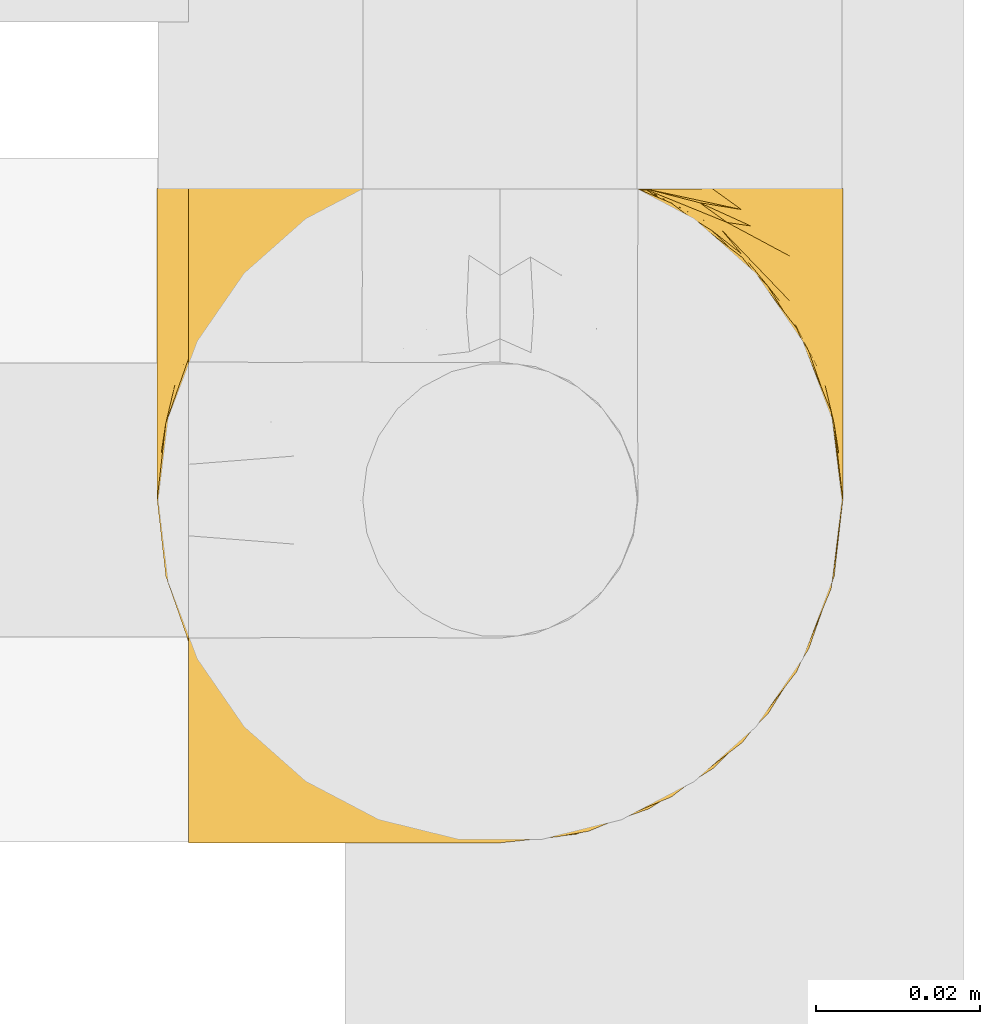
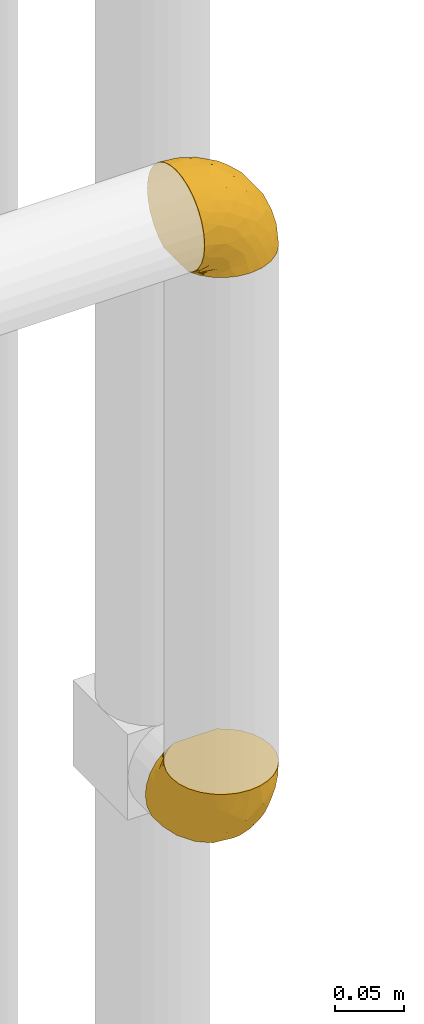
# One storey, part 352 of 827: 2 coverings.
"""IFC2X3 building model written with IfcOpenShell, lengths in millimetres."""

from ifc_helpers import new_model, entity, si_unit, converted_unit, derived_unit, direction, frame, origin, place, context, subcontext, project, spatial, faceted_brep, element, save


model = new_model("IFC2X3")

# Units and contexts
model_context = context("Model", 3, precision=0.01, world=origin(), true_north=direction((6.12303176911189e-17, 1.0)))
body_context = subcontext(model_context, "Body", "Model", "MODEL_VIEW")
ifc_project = project(units=[si_unit("LENGTHUNIT", "METRE", prefix="MILLI"), si_unit("AREAUNIT", "SQUARE_METRE"), si_unit("VOLUMEUNIT", "CUBIC_METRE"), converted_unit("PLANEANGLEUNIT", "DEGREE", entity("IfcRatioMeasure", 0.0174532925199433), si_unit("PLANEANGLEUNIT", "RADIAN"), dimensions=[0, 0, 0, 0, 0, 0, 0]), si_unit("MASSUNIT", "GRAM", prefix="KILO"), derived_unit("MASSDENSITYUNIT", [(si_unit("MASSUNIT", "GRAM", prefix="KILO"), 1), (si_unit("LENGTHUNIT", "METRE"), -3)]), derived_unit("MOMENTOFINERTIAUNIT", [(si_unit("LENGTHUNIT", "METRE"), 4)]), si_unit("TIMEUNIT", "SECOND"), si_unit("FREQUENCYUNIT", "HERTZ"), si_unit("THERMODYNAMICTEMPERATUREUNIT", "DEGREE_CELSIUS"), derived_unit("THERMALTRANSMITTANCEUNIT", [(si_unit("MASSUNIT", "GRAM", prefix="KILO"), 1), (si_unit("THERMODYNAMICTEMPERATUREUNIT", "KELVIN"), -1), (si_unit("TIMEUNIT", "SECOND"), -3)]), derived_unit("VOLUMETRICFLOWRATEUNIT", [(si_unit("LENGTHUNIT", "METRE"), 3), (si_unit("TIMEUNIT", "SECOND"), -1)]), derived_unit("MASSFLOWRATEUNIT", [(si_unit("MASSUNIT", "GRAM", prefix="KILO"), 1), (si_unit("TIMEUNIT", "SECOND"), -1)]), derived_unit("ROTATIONALFREQUENCYUNIT", [(si_unit("TIMEUNIT", "SECOND"), -1)]), si_unit("ELECTRICCURRENTUNIT", "AMPERE"), si_unit("ELECTRICVOLTAGEUNIT", "VOLT"), si_unit("POWERUNIT", "WATT"), si_unit("FORCEUNIT", "NEWTON", prefix="KILO"), si_unit("ILLUMINANCEUNIT", "LUX"), si_unit("LUMINOUSFLUXUNIT", "LUMEN"), si_unit("LUMINOUSINTENSITYUNIT", "CANDELA"), derived_unit("USERDEFINED", [(si_unit("MASSUNIT", "GRAM", prefix="KILO"), -1), (si_unit("LENGTHUNIT", "METRE"), -2), (si_unit("TIMEUNIT", "SECOND"), 3), (si_unit("LUMINOUSFLUXUNIT", "LUMEN"), 1)]), derived_unit("LINEARVELOCITYUNIT", [(si_unit("LENGTHUNIT", "METRE"), 1), (si_unit("TIMEUNIT", "SECOND"), -1)]), si_unit("PRESSUREUNIT", "PASCAL"), derived_unit("USERDEFINED", [(si_unit("LENGTHUNIT", "METRE"), -2), (si_unit("MASSUNIT", "GRAM", prefix="KILO"), 1), (si_unit("TIMEUNIT", "SECOND"), -2)]), derived_unit("LINEARFORCEUNIT", [(si_unit("MASSUNIT", "GRAM", prefix="KILO"), 1), (si_unit("LENGTHUNIT", "METRE"), 1), (si_unit("TIMEUNIT", "SECOND"), -2), (si_unit("LENGTHUNIT", "METRE"), -1)]), derived_unit("PLANARFORCEUNIT", [(si_unit("MASSUNIT", "GRAM", prefix="KILO"), 1), (si_unit("LENGTHUNIT", "METRE"), 1), (si_unit("TIMEUNIT", "SECOND"), -2), (si_unit("LENGTHUNIT", "METRE"), -2)])], contexts=[model_context])

# Site, building, storey
site_placement = place(None, origin())
site = spatial("IfcSite", under=ifc_project, at=site_placement, CompositionType="ELEMENT")
building_placement = place(site_placement, origin())
building = spatial("IfcBuilding", under=site, at=building_placement, CompositionType="ELEMENT")
storey_placement = place(building_placement, frame((0.0, 0.0, 28200.0)))
storey = spatial("IfcBuildingStorey", under=building, at=storey_placement, Name="08", CompositionType="ELEMENT", Elevation=28200.0)

# Coverings
covering_1_placement = place(storey_placement, frame((43532.77, 15137.81, 1655.84)))
element("IfcCovering", 1, at=covering_1_placement, inside=storey, Name=":ADSK_", ObjectType=":ADSK_", PredefinedType="INSULATION", context=body_context, shape_type="Brep", body=[
    faceted_brep([(5.74, 25.28, 81.45), (10.73, 17.35, 81.45), (17.36, 10.72, 81.45), (25.29, 5.74, 81.45), (34.14, 2.64, 81.45), (43.45, 1.6, 81.45), (52.76, 2.65, 81.45), (61.61, 5.74, 81.45), (69.54, 10.73, 81.45), (76.17, 17.36, 81.45), (81.15, 25.29, 81.45), (84.25, 34.14, 81.45), (85.3, 43.45, 81.45), (84.23, 52.82, 81.45), (81.1, 61.71, 81.45), (76.06, 69.67, 81.45), (69.36, 76.31, 81.45), (61.36, 81.27, 81.45), (60.44, 81.27, 81.45), (59.52, 81.27, 81.45), (58.72, 81.27, 81.45), (57.4, 81.27, 81.45), (56.08, 81.27, 81.45), (54.76, 81.27, 81.45), (53.44, 81.27, 81.45), (52.12, 81.27, 81.45), (50.8, 81.27, 81.45), (49.47, 81.27, 81.45), (48.15, 81.27, 81.45), (46.83, 81.27, 81.45), (45.51, 81.27, 81.45), (44.19, 81.27, 81.45), (42.87, 81.27, 81.45), (41.55, 81.27, 81.45), (40.23, 81.27, 81.45), (39.31, 81.27, 81.45), (38.39, 81.27, 81.45), (37.48, 81.27, 81.45), (36.56, 81.27, 81.45), (35.64, 81.27, 81.45), (34.72, 81.27, 81.45), (33.8, 81.27, 81.45), (32.88, 81.27, 81.45), (31.96, 81.27, 81.45), (31.05, 81.27, 81.45), (30.13, 81.27, 81.45), (29.21, 81.27, 81.45), (28.29, 81.27, 81.45), (27.37, 81.27, 81.45), (26.45, 81.27, 81.45), (25.53, 81.27, 81.45), (17.52, 76.3, 81.45), (10.82, 69.66, 81.45), (5.78, 61.69, 81.45), (2.65, 52.8, 81.45), (1.6, 43.45, 81.45), (2.65, 34.13, 81.45), (69.37, 81.45, 76.3), (76.06, 81.45, 69.67), (81.1, 81.45, 61.7), (84.23, 81.45, 52.81), (85.3, 81.45, 43.45), (83.87, 81.45, 32.61), (79.69, 81.45, 22.52), (73.04, 81.45, 13.85), (64.37, 81.45, 7.2), (54.28, 81.45, 3.02), (43.45, 81.45, 1.6), (32.61, 81.45, 3.02), (22.52, 81.45, 7.2), (13.85, 81.45, 13.85), (7.2, 81.45, 22.52), (3.02, 81.45, 32.61), (1.6, 81.45, 43.45), (2.66, 81.45, 52.81), (5.79, 81.45, 61.7), (10.83, 81.45, 69.67), (17.52, 81.45, 76.3), (25.53, 81.45, 81.27), (26.45, 81.45, 81.27), (27.77, 81.45, 81.27), (28.89, 81.45, 81.27), (30.01, 81.45, 81.27), (31.13, 81.45, 81.27), (32.25, 81.45, 81.27), (33.37, 81.45, 81.27), (34.49, 81.45, 81.27), (35.61, 81.45, 81.27), (36.73, 81.45, 81.27), (37.85, 81.45, 81.27), (38.97, 81.45, 81.27), (40.09, 81.45, 81.27), (41.21, 81.45, 81.27), (42.33, 81.45, 81.27), (43.45, 81.45, 81.27), (44.77, 81.45, 81.27), (46.09, 81.45, 81.27), (47.41, 81.45, 81.27), (48.73, 81.45, 81.27), (50.05, 81.45, 81.27), (51.37, 81.45, 81.27), (52.69, 81.45, 81.27), (54.01, 81.45, 81.27), (54.93, 81.45, 81.27), (55.85, 81.45, 81.27), (56.76, 81.45, 81.27), (57.68, 81.45, 81.27), (58.6, 81.45, 81.27), (59.52, 81.45, 81.27), (60.44, 81.45, 81.27), (61.36, 81.45, 81.27), (32.81, 81.33, 81.31), (31.73, 81.32, 81.33), (50.71, 81.33, 81.31), (51.76, 81.32, 81.32), (42.89, 81.33, 81.31), (41.81, 81.32, 81.32), (25.53, 81.32, 81.32), (26.91, 81.32, 81.32), (40.71, 81.32, 81.32), (60.15, 81.32, 81.32), (39.53, 81.32, 81.32), (57.22, 81.32, 81.32), (58.17, 81.34, 81.3), (47.12, 81.32, 81.32), (33.93, 81.31, 81.33), (35.05, 81.33, 81.31), (46.09, 81.31, 81.33), (45.02, 81.32, 81.32), (43.95, 81.33, 81.32), (59.12, 81.32, 81.32), (38.49, 81.33, 81.31), (49.68, 81.32, 81.32), (53.35, 81.33, 81.31), (54.4, 81.32, 81.32), (56.2, 81.32, 81.32), (36.2, 81.32, 81.32), (37.29, 81.31, 81.33), (30.57, 81.32, 81.32), (29.45, 81.33, 81.31), (28.01, 81.31, 81.33), (61.36, 81.32, 81.32), (25.53, 81.3, 81.36), (25.53, 81.29, 81.4), (61.36, 81.29, 81.4), (61.36, 81.3, 81.36), (25.53, 81.4, 81.29), (25.53, 81.36, 81.3), (61.36, 81.36, 81.3), (61.36, 81.4, 81.29), (55.3, 81.3, 81.35), (48.18, 81.33, 81.31), (82.92, 74.06, 58.5), (85.3, 45.99, 71.95), (82.92, 58.35, 74.57), (78.8, 67.76, 73.93), (78.8, 66.18, 78.18), (70.46, 76.46, 78.04), (71.16, 77.33, 76.23), (85.3, 71.95, 45.99), (76.1, 72.25, 74.01), (72.9, 78.91, 73.57), (78.81, 76.42, 66.66), (72.89, 73.52, 79.09), (74.06, 76.9, 73.14), (83.71, 65.25, 60.34), (85.3, 62.45, 48.54), (85.3, 74.31, 45.36), (83.61, 59.38, 67.22), (85.3, 48.54, 62.45), (80.61, 67.72, 68.67), (85.3, 55.49, 55.49), (67.83, 79.73, 77.84), (78.81, 73.23, 68.16), (85.3, 45.36, 74.31), (54.78, 15.81, 38.78), (57.27, 6.4, 62.1), (43.45, 7.67, 50.89), (84.45, 68.46, 36.91), (84.39, 59.33, 40.37), (77.16, 48.7, 27.86), (68.92, 53.94, 15.77), (76.65, 65.02, 20.13), (82.11, 60.77, 31.54), (82.11, 72.07, 28.25), (78.88, 26.25, 57.26), (78.88, 22.29, 69.99), (73.04, 16.0, 64.58), (84.47, 46.93, 50.64), (65.72, 14.19, 51.97), (51.16, 58.46, 5.72), (59.46, 61.51, 7.42), (43.45, 4.64, 66.14), (68.92, 68.93, 11.35), (51.18, 29.62, 21.64), (57.42, 24.85, 28.57), (83.48, 38.55, 55.38), (82.95, 31.27, 68.51), (65.72, 9.35, 67.48), (78.97, 37.15, 40.78), (82.64, 47.07, 41.53), (75.14, 26.49, 46.11), (68.58, 23.01, 40.32), (61.95, 19.4, 38.36), (58.11, 48.06, 11.84), (51.07, 42.46, 12.56), (43.45, 50.89, 7.67), (58.51, 35.78, 19.39), (43.45, 24.98, 24.98), (43.45, 16.33, 37.94), (43.45, 66.14, 4.64), (65.68, 30.96, 28.09), (70.41, 41.83, 23.73), (73.04, 33.28, 34.03), (43.45, 37.94, 16.33), (4.78, 67.39, 29.29), (35.48, 58.47, 5.77), (29.45, 32.5, 21.44), (32.11, 15.79, 38.8), (13.86, 15.99, 64.58), (21.19, 9.34, 67.49), (10.24, 56.91, 22.9), (17.97, 63.5, 12.54), (18.88, 44.08, 20.04), (8.01, 26.24, 57.26), (8.01, 22.27, 69.99), (3.95, 31.26, 68.51), (22.45, 23.95, 34.54), (2.4, 63.79, 38.81), (1.6, 62.45, 48.54), (1.6, 71.95, 45.99), (1.6, 45.36, 74.31), (29.05, 67.83, 5.36), (10.24, 70.28, 18.96), (35.7, 42.11, 12.79), (29.63, 6.39, 62.11), (8.75, 43.54, 33.14), (4.54, 58.03, 33.44), (21.19, 14.18, 51.98), (2.28, 56.34, 43.42), (2.53, 48.09, 48.62), (1.6, 48.54, 62.45), (1.6, 55.49, 55.49), (13.86, 21.78, 49.68), (3.41, 38.54, 55.37), (1.6, 45.99, 71.95), (2.35, 72.79, 36.37), (13.86, 33.26, 34.04), (7.35, 35.53, 44.1), (27.43, 53.66, 9.99), (13.39, 43.03, 26.41), (4.32, 49.68, 39.19), (3.97, 74.06, 58.5), (3.27, 59.37, 67.22), (3.97, 58.34, 74.57), (8.08, 67.75, 73.92), (13.99, 78.91, 73.57), (12.83, 76.9, 73.14), (8.08, 78.08, 66.19), (8.08, 73.23, 68.16), (19.06, 79.73, 77.84), (15.74, 77.34, 76.23), (13.98, 73.51, 79.08), (16.42, 76.45, 78.04), (8.08, 66.41, 77.18), (6.27, 67.7, 68.66), (10.78, 72.24, 74.0), (3.18, 65.25, 60.34)], [[[0, 1, 2, 3, 4, 5, 6, 7, 8, 9, 10, 11, 12, 13, 14, 15, 16, 17, 18, 19, 20, 21, 22, 23, 24, 25, 26, 27, 28, 29, 30, 31, 32, 33, 34, 35, 36, 37, 38, 39, 40, 41, 42, 43, 44, 45, 46, 47, 48, 49, 50, 51, 52, 53, 54, 55, 56]], [[57, 58, 59, 60, 61, 62, 63, 64, 65, 66, 67, 68, 69, 70, 71, 72, 73, 74, 75, 76, 77, 78, 79, 80, 81, 82, 83, 84, 85, 86, 87, 88, 89, 90, 91, 92, 93, 94, 95, 96, 97, 98, 99, 100, 101, 102, 103, 104, 105, 106, 107, 108, 109, 110]], [[111, 84, 112]], [[113, 26, 114]], [[114, 101, 100]], [[115, 93, 116]], [[79, 117, 118]], [[33, 116, 119]], [[117, 49, 118]], [[19, 18, 120]], [[119, 121, 34]], [[122, 21, 123]], [[97, 96, 124]], [[86, 125, 126]], [[116, 92, 119]], [[127, 96, 128]], [[32, 129, 115]], [[19, 120, 130]], [[121, 90, 131]], [[94, 115, 129]], [[115, 116, 32]], [[118, 49, 48]], [[113, 99, 132]], [[133, 114, 25]], [[24, 134, 133]], [[135, 22, 122]], [[136, 137, 88]], [[84, 83, 112]], [[138, 82, 139]], [[130, 20, 19]], [[118, 48, 140]], [[81, 140, 139]], [[123, 21, 20]], [[141, 120, 18]], [[139, 82, 81]], [[130, 107, 123]], [[49, 117, 142, 143, 50]], [[18, 17, 144, 145, 141]], [[79, 78, 146, 147, 117]], [[109, 141, 148, 149, 110]], [[102, 133, 134]], [[105, 135, 122]], [[118, 80, 79]], [[80, 118, 140]], [[120, 109, 108]], [[47, 46, 140, 48]], [[81, 80, 140]], [[44, 112, 138]], [[93, 115, 94]], [[46, 139, 140]], [[46, 45, 139]], [[139, 45, 138]], [[138, 112, 83]], [[85, 84, 111]], [[112, 43, 111]], [[83, 82, 138]], [[106, 122, 123]], [[105, 122, 106]], [[21, 122, 22]], [[124, 29, 28]], [[33, 32, 116]], [[128, 129, 31]], [[32, 31, 129]], [[34, 33, 119]], [[116, 93, 92]], [[129, 95, 94]], [[95, 129, 128]], [[41, 40, 125, 42]], [[119, 91, 121]], [[36, 35, 131, 37]], [[137, 131, 89]], [[121, 131, 35]], [[90, 121, 91]], [[119, 92, 91]], [[136, 126, 39]], [[125, 86, 85]], [[42, 125, 111]], [[85, 111, 125]], [[150, 23, 22]], [[130, 108, 107]], [[130, 123, 20]], [[107, 106, 123]], [[137, 37, 131]], [[136, 38, 137]], [[89, 88, 137]], [[131, 90, 89]], [[124, 151, 97]], [[40, 39, 126]], [[87, 126, 136]], [[86, 126, 87]], [[136, 88, 87]], [[40, 126, 125]], [[39, 38, 136]], [[95, 128, 96]], [[30, 128, 31]], [[29, 124, 127]], [[127, 128, 30]], [[151, 124, 28]], [[127, 30, 29]], [[127, 124, 96]], [[151, 98, 97]], [[45, 44, 138]], [[26, 113, 132]], [[113, 100, 99]], [[132, 151, 27]], [[27, 26, 132]], [[26, 25, 114]], [[100, 113, 114]], [[101, 133, 102]], [[133, 101, 114]], [[28, 27, 151]], [[132, 99, 98]], [[23, 134, 24]], [[25, 24, 133]], [[134, 23, 150]], [[135, 104, 150]], [[150, 104, 103]], [[103, 102, 134]], [[130, 120, 108]], [[109, 120, 141]], [[42, 111, 43]], [[112, 44, 43]], [[104, 135, 105]], [[134, 150, 103]], [[135, 150, 22]], [[35, 34, 121]], [[137, 38, 37]], [[98, 151, 132]], [[59, 152, 60]], [[13, 153, 154]], [[155, 156, 154]], [[157, 158, 141]], [[159, 60, 152]], [[160, 157, 155]], [[161, 162, 58]], [[58, 162, 59]], [[144, 16, 163]], [[58, 57, 161]], [[162, 161, 164]], [[157, 163, 155]], [[163, 16, 15]], [[57, 149, 161]], [[152, 165, 166]], [[157, 144, 163]], [[60, 159, 167, 61]], [[156, 14, 154]], [[163, 156, 155]], [[155, 154, 168]], [[168, 154, 169]], [[155, 170, 160]], [[57, 110, 149]], [[144, 17, 16]], [[156, 15, 14]], [[171, 165, 168]], [[158, 164, 172]], [[14, 13, 154]], [[157, 141, 145, 144]], [[173, 164, 158]], [[173, 160, 170]], [[171, 166, 165]], [[168, 165, 170]], [[168, 169, 171]], [[152, 173, 165]], [[170, 155, 168]], [[165, 173, 170]], [[160, 173, 158]], [[172, 149, 148]], [[148, 141, 158]], [[158, 157, 160]], [[152, 166, 159]], [[173, 152, 162]], [[59, 162, 152]], [[13, 12, 174, 153]], [[153, 169, 154]], [[15, 156, 163]], [[162, 164, 173]], [[172, 164, 161]], [[149, 172, 161]], [[158, 172, 148]], [[175, 176, 177]], [[178, 166, 179]], [[180, 181, 182]], [[183, 184, 178]], [[185, 186, 187]], [[171, 188, 179]], [[174, 12, 11]], [[189, 176, 175]], [[190, 66, 191]], [[176, 6, 192]], [[193, 65, 64]], [[63, 184, 182]], [[63, 182, 64]], [[65, 193, 191]], [[184, 63, 62]], [[175, 194, 195]], [[196, 169, 197]], [[174, 11, 197]], [[8, 7, 198]], [[187, 9, 8]], [[197, 169, 153, 174]], [[197, 11, 10]], [[186, 197, 10]], [[199, 180, 200]], [[197, 185, 196]], [[201, 189, 202]], [[201, 187, 189]], [[195, 203, 175]], [[191, 204, 190]], [[176, 7, 6]], [[177, 176, 192]], [[189, 198, 176]], [[65, 191, 66]], [[198, 187, 8]], [[205, 206, 190]], [[9, 186, 10]], [[181, 207, 204]], [[208, 175, 177, 209]], [[66, 190, 210]], [[211, 212, 213]], [[190, 204, 205]], [[180, 182, 183]], [[193, 182, 181]], [[62, 61, 167]], [[196, 185, 199]], [[196, 200, 188]], [[6, 5, 192]], [[176, 198, 7]], [[187, 198, 189]], [[187, 186, 9]], [[197, 186, 185]], [[200, 180, 183]], [[180, 213, 212]], [[179, 183, 178]], [[185, 201, 199]], [[210, 190, 206]], [[210, 67, 66]], [[205, 204, 207]], [[194, 205, 207]], [[194, 214, 205]], [[195, 194, 207]], [[208, 194, 175]], [[207, 211, 195]], [[202, 203, 211]], [[212, 207, 181]], [[202, 211, 213]], [[201, 202, 213]], [[189, 175, 203]], [[199, 201, 213]], [[187, 201, 185]], [[180, 199, 213]], [[196, 199, 200]], [[211, 203, 195]], [[189, 203, 202]], [[207, 212, 211]], [[180, 212, 181]], [[214, 194, 208]], [[214, 206, 205]], [[196, 188, 169]], [[181, 204, 191]], [[182, 193, 64]], [[191, 193, 181]], [[178, 62, 167]], [[182, 184, 183]], [[62, 178, 184]], [[178, 167, 159, 166]], [[171, 179, 166]], [[200, 183, 179]], [[179, 188, 200]], [[169, 188, 171]], [[71, 215, 72]], [[206, 216, 210]], [[217, 208, 218]], [[216, 68, 210]], [[219, 220, 2]], [[221, 222, 223]], [[224, 225, 226]], [[227, 223, 217]], [[228, 229, 230]], [[56, 231, 226]], [[232, 222, 69]], [[56, 55, 231]], [[70, 233, 71]], [[71, 233, 215]], [[0, 56, 226]], [[208, 217, 234]], [[218, 177, 235]], [[221, 236, 237]], [[238, 220, 219]], [[1, 219, 2]], [[68, 216, 232]], [[235, 3, 220]], [[235, 192, 4]], [[1, 0, 225]], [[228, 239, 229]], [[240, 241, 242]], [[243, 238, 219]], [[224, 226, 244]], [[226, 241, 244]], [[3, 235, 4]], [[69, 222, 70]], [[225, 219, 1]], [[218, 235, 238]], [[243, 219, 224]], [[218, 227, 217]], [[3, 2, 220]], [[218, 208, 209, 177]], [[226, 231, 245, 241]], [[215, 228, 246]], [[247, 248, 236]], [[248, 224, 244]], [[223, 222, 249]], [[233, 222, 221]], [[242, 239, 240]], [[248, 247, 243]], [[217, 223, 249]], [[250, 247, 236]], [[216, 234, 249]], [[218, 238, 227]], [[192, 235, 177]], [[192, 5, 4]], [[72, 246, 73]], [[235, 220, 238]], [[226, 225, 0]], [[219, 225, 224]], [[240, 248, 244]], [[239, 242, 229]], [[236, 248, 251]], [[68, 67, 210]], [[234, 216, 206]], [[216, 249, 232]], [[234, 206, 214, 208]], [[249, 234, 217]], [[222, 232, 249]], [[69, 68, 232]], [[246, 228, 230]], [[237, 228, 215]], [[243, 227, 238]], [[223, 227, 247]], [[73, 246, 230]], [[215, 246, 72]], [[248, 243, 224]], [[227, 243, 247]], [[237, 236, 251]], [[250, 221, 223]], [[222, 233, 70]], [[215, 233, 221]], [[221, 237, 215]], [[239, 237, 251]], [[237, 239, 228]], [[239, 251, 240]], [[248, 240, 251]], [[241, 240, 244]], [[221, 250, 236]], [[223, 247, 250]], [[74, 230, 252]], [[253, 254, 255]], [[146, 77, 256]], [[257, 258, 259]], [[260, 256, 257]], [[260, 261, 147]], [[75, 74, 252]], [[51, 143, 262]], [[263, 143, 142, 117]], [[256, 77, 76]], [[252, 258, 75]], [[253, 241, 254]], [[254, 245, 54]], [[258, 256, 76]], [[53, 52, 264]], [[255, 265, 253]], [[254, 264, 255]], [[255, 264, 262]], [[75, 258, 76]], [[265, 255, 266]], [[255, 262, 263]], [[51, 50, 143]], [[54, 245, 231, 55]], [[51, 262, 52]], [[253, 267, 242]], [[254, 54, 53]], [[266, 259, 265]], [[146, 78, 77]], [[263, 117, 261]], [[146, 256, 260]], [[257, 259, 261]], [[267, 253, 265]], [[229, 267, 252]], [[242, 267, 229]], [[242, 241, 253]], [[252, 267, 259]], [[255, 263, 266]], [[259, 267, 265]], [[261, 117, 147]], [[263, 261, 266]], [[259, 266, 261]], [[230, 74, 73]], [[230, 229, 252]], [[259, 258, 252]], [[254, 241, 245]], [[53, 264, 254]], [[52, 262, 264]], [[143, 263, 262]], [[258, 257, 256]], [[261, 260, 257]], [[146, 260, 147]]]),
])
covering_2_placement = place(storey_placement, frame((43536.62, 15137.81, 2194.69)))
element("IfcCovering", 2, at=covering_2_placement, inside=storey, Name=":ADSK_", ObjectType=":ADSK_", PredefinedType="INSULATION", context=body_context, shape_type="Brep", body=[
    faceted_brep([(1.6, 5.74, 57.76), (1.6, 10.73, 65.69), (1.6, 17.36, 72.32), (1.6, 25.29, 77.3), (1.6, 34.14, 80.4), (1.6, 43.45, 81.45), (1.6, 52.76, 80.39), (1.6, 61.61, 77.3), (1.6, 69.54, 72.31), (1.6, 76.17, 65.68), (1.6, 81.15, 57.75), (1.6, 84.25, 48.9), (1.6, 85.3, 39.6), (1.6, 84.23, 30.22), (1.6, 81.1, 21.33), (1.6, 76.06, 13.37), (1.6, 69.36, 6.73), (1.6, 61.36, 1.77), (1.6, 60.44, 1.77), (1.6, 59.52, 1.77), (1.6, 58.72, 1.77), (1.6, 57.4, 1.77), (1.6, 56.08, 1.77), (1.6, 54.76, 1.77), (1.6, 53.44, 1.77), (1.6, 52.12, 1.77), (1.6, 50.8, 1.77), (1.6, 49.47, 1.77), (1.6, 48.15, 1.77), (1.6, 46.83, 1.77), (1.6, 45.51, 1.77), (1.6, 44.19, 1.77), (1.6, 42.87, 1.77), (1.6, 41.55, 1.77), (1.6, 40.23, 1.77), (1.6, 39.31, 1.77), (1.6, 38.39, 1.77), (1.6, 37.48, 1.77), (1.6, 36.56, 1.77), (1.6, 35.64, 1.77), (1.6, 34.72, 1.77), (1.6, 33.8, 1.77), (1.6, 32.88, 1.77), (1.6, 31.96, 1.77), (1.6, 31.05, 1.77), (1.6, 30.13, 1.77), (1.6, 29.21, 1.77), (1.6, 28.29, 1.77), (1.6, 27.37, 1.77), (1.6, 26.45, 1.77), (1.6, 25.53, 1.77), (1.6, 17.52, 6.74), (1.6, 10.82, 13.38), (1.6, 5.78, 21.35), (1.6, 2.65, 30.24), (1.6, 1.6, 39.6), (1.6, 2.65, 48.91), (6.74, 69.37, 1.6), (13.37, 76.06, 1.6), (21.34, 81.1, 1.6), (30.23, 84.23, 1.6), (39.6, 85.3, 1.6), (50.43, 83.87, 1.6), (60.52, 79.69, 1.6), (69.19, 73.04, 1.6), (75.84, 64.37, 1.6), (80.02, 54.28, 1.6), (81.45, 43.45, 1.6), (80.02, 32.61, 1.6), (75.84, 22.52, 1.6), (69.19, 13.85, 1.6), (60.52, 7.2, 1.6), (50.43, 3.02, 1.6), (39.6, 1.6, 1.6), (30.23, 2.66, 1.6), (21.34, 5.79, 1.6), (13.37, 10.83, 1.6), (6.74, 17.52, 1.6), (1.77, 25.53, 1.6), (1.77, 26.45, 1.6), (1.77, 27.77, 1.6), (1.77, 28.89, 1.6), (1.77, 30.01, 1.6), (1.77, 31.13, 1.6), (1.77, 32.25, 1.6), (1.77, 33.37, 1.6), (1.77, 34.49, 1.6), (1.77, 35.61, 1.6), (1.77, 36.73, 1.6), (1.77, 37.85, 1.6), (1.77, 38.97, 1.6), (1.77, 40.09, 1.6), (1.77, 41.21, 1.6), (1.77, 42.33, 1.6), (1.77, 43.45, 1.6), (1.77, 44.77, 1.6), (1.77, 46.09, 1.6), (1.77, 47.41, 1.6), (1.77, 48.73, 1.6), (1.77, 50.05, 1.6), (1.77, 51.37, 1.6), (1.77, 52.69, 1.6), (1.77, 54.01, 1.6), (1.77, 54.93, 1.6), (1.77, 55.85, 1.6), (1.77, 56.76, 1.6), (1.77, 57.68, 1.6), (1.77, 58.6, 1.6), (1.77, 59.52, 1.6), (1.77, 60.44, 1.6), (1.77, 61.36, 1.6), (1.73, 32.81, 1.71), (1.72, 31.73, 1.73), (1.73, 50.71, 1.71), (1.72, 51.76, 1.72), (1.73, 42.89, 1.71), (1.73, 41.81, 1.72), (1.72, 25.53, 1.72), (1.72, 26.91, 1.72), (1.72, 40.71, 1.72), (1.72, 60.15, 1.72), (1.72, 39.53, 1.72), (1.73, 57.22, 1.72), (1.74, 58.17, 1.7), (1.72, 47.12, 1.72), (1.71, 33.93, 1.73), (1.73, 35.05, 1.72), (1.71, 46.09, 1.73), (1.72, 45.02, 1.73), (1.73, 43.95, 1.72), (1.72, 59.12, 1.72), (1.73, 38.49, 1.71), (1.72, 49.68, 1.72), (1.73, 53.35, 1.71), (1.72, 54.4, 1.72), (1.72, 56.2, 1.72), (1.72, 36.2, 1.72), (1.71, 37.29, 1.73), (1.72, 30.57, 1.72), (1.73, 29.45, 1.71), (1.71, 28.01, 1.73), (1.72, 61.36, 1.72), (1.68, 25.53, 1.74), (1.64, 25.53, 1.75), (1.64, 61.36, 1.75), (1.68, 61.36, 1.74), (1.75, 25.53, 1.64), (1.74, 25.53, 1.68), (1.74, 61.36, 1.68), (1.75, 61.36, 1.64), (1.7, 55.3, 1.74), (1.73, 48.18, 1.71), (24.54, 82.92, 8.98), (11.1, 85.3, 37.05), (8.47, 82.92, 24.69), (9.11, 78.8, 15.28), (4.86, 78.8, 16.86), (5.0, 70.46, 6.58), (6.81, 71.16, 5.71), (37.05, 85.3, 11.1), (9.03, 76.1, 10.79), (9.47, 72.9, 4.13), (16.39, 78.81, 6.62), (3.95, 72.89, 9.52), (9.9, 74.06, 6.14), (22.7, 83.71, 17.79), (34.5, 85.3, 20.6), (37.68, 85.3, 8.73), (15.82, 83.61, 23.66), (20.6, 85.3, 34.5), (14.37, 80.61, 15.32), (27.55, 85.3, 27.55), (5.2, 67.83, 3.31), (14.88, 78.81, 9.81), (8.73, 85.3, 37.68), (44.27, 54.78, 67.23), (20.94, 57.27, 76.64), (32.15, 43.45, 75.37), (46.13, 84.45, 14.58), (42.67, 84.39, 23.71), (55.18, 77.16, 34.34), (67.27, 68.92, 29.1), (62.91, 76.65, 18.02), (51.5, 82.11, 22.27), (54.79, 82.11, 10.97), (25.78, 78.88, 56.79), (13.05, 78.88, 60.76), (18.46, 73.04, 67.04), (32.4, 84.47, 36.11), (31.07, 65.72, 68.85), (77.32, 51.16, 24.58), (75.62, 59.46, 21.54), (16.9, 43.45, 78.4), (71.69, 68.92, 14.11), (61.4, 51.18, 53.42), (54.47, 57.42, 58.19), (27.66, 83.48, 44.49), (14.53, 82.95, 51.77), (15.56, 65.72, 73.69), (42.26, 78.97, 45.89), (41.51, 82.64, 35.97), (36.93, 75.14, 56.55), (42.72, 68.58, 60.03), (44.68, 61.95, 63.64), (71.2, 58.11, 34.98), (70.48, 51.07, 40.58), (75.37, 43.45, 32.15), (63.65, 58.51, 47.26), (58.06, 43.45, 58.06), (45.11, 43.45, 66.71), (78.4, 43.45, 16.9), (54.95, 65.68, 52.08), (59.31, 70.41, 41.21), (49.01, 73.04, 49.76), (66.71, 43.45, 45.11), (53.75, 4.78, 15.65), (77.27, 35.48, 24.57), (61.6, 29.45, 50.54), (44.24, 32.11, 67.25), (18.46, 13.86, 67.06), (15.55, 21.19, 73.7), (60.14, 10.24, 26.13), (70.5, 17.97, 19.54), (63.0, 18.88, 38.96), (25.78, 8.01, 56.8), (13.05, 8.01, 60.77), (14.53, 3.95, 51.78), (48.5, 22.45, 59.09), (44.23, 2.4, 19.25), (34.5, 1.6, 20.6), (37.05, 1.6, 11.1), (8.73, 1.6, 37.68), (77.68, 29.05, 15.21), (64.08, 10.24, 12.76), (70.25, 35.7, 40.93), (20.93, 29.63, 76.65), (49.9, 8.75, 39.5), (49.6, 4.54, 25.01), (31.06, 21.19, 68.86), (39.62, 2.28, 26.7), (34.42, 2.53, 34.95), (20.6, 1.6, 34.5), (27.55, 1.6, 27.55), (33.36, 13.86, 61.27), (27.68, 3.41, 44.5), (11.1, 1.6, 37.05), (46.67, 2.35, 10.25), (49.0, 13.86, 49.78), (38.94, 7.35, 47.51), (73.05, 27.43, 29.38), (56.63, 13.39, 40.01), (43.85, 4.32, 33.36), (24.54, 3.97, 8.98), (15.82, 3.27, 23.67), (8.47, 3.97, 24.71), (9.12, 8.08, 15.29), (9.47, 13.99, 4.13), (9.91, 12.83, 6.14), (16.85, 8.08, 4.96), (14.88, 8.08, 9.81), (5.2, 19.06, 3.31), (6.81, 15.74, 5.7), (3.96, 13.98, 9.53), (5.0, 16.42, 6.59), (5.86, 8.08, 16.63), (14.38, 6.27, 15.34), (9.04, 10.78, 10.8), (22.7, 3.18, 17.79)], [[[0, 1, 2, 3, 4, 5, 6, 7, 8, 9, 10, 11, 12, 13, 14, 15, 16, 17, 18, 19, 20, 21, 22, 23, 24, 25, 26, 27, 28, 29, 30, 31, 32, 33, 34, 35, 36, 37, 38, 39, 40, 41, 42, 43, 44, 45, 46, 47, 48, 49, 50, 51, 52, 53, 54, 55, 56]], [[57, 58, 59, 60, 61, 62, 63, 64, 65, 66, 67, 68, 69, 70, 71, 72, 73, 74, 75, 76, 77, 78, 79, 80, 81, 82, 83, 84, 85, 86, 87, 88, 89, 90, 91, 92, 93, 94, 95, 96, 97, 98, 99, 100, 101, 102, 103, 104, 105, 106, 107, 108, 109, 110]], [[111, 84, 112]], [[113, 26, 114]], [[114, 101, 100]], [[115, 93, 116]], [[79, 117, 118]], [[33, 116, 119]], [[117, 49, 118]], [[19, 18, 120]], [[119, 121, 34]], [[122, 21, 123]], [[97, 96, 124]], [[86, 125, 126]], [[116, 92, 119]], [[127, 96, 128]], [[32, 129, 115]], [[19, 120, 130]], [[121, 90, 131]], [[94, 115, 129]], [[115, 116, 32]], [[118, 49, 48]], [[113, 99, 132]], [[133, 114, 25]], [[24, 134, 133]], [[135, 22, 122]], [[136, 137, 88]], [[84, 83, 112]], [[138, 82, 139]], [[130, 20, 19]], [[118, 48, 140]], [[81, 140, 139]], [[123, 21, 20]], [[141, 120, 18]], [[139, 82, 81]], [[130, 107, 123]], [[49, 117, 142, 143, 50]], [[18, 17, 144, 145, 141]], [[79, 78, 146, 147, 117]], [[109, 141, 148, 149, 110]], [[102, 133, 134]], [[105, 135, 122]], [[118, 80, 79]], [[80, 118, 140]], [[120, 109, 108]], [[47, 46, 140, 48]], [[81, 80, 140]], [[44, 112, 138]], [[93, 115, 94]], [[46, 139, 140]], [[46, 45, 139]], [[139, 45, 138]], [[138, 112, 83]], [[85, 84, 111]], [[112, 43, 111]], [[83, 82, 138]], [[106, 122, 123]], [[105, 122, 106]], [[21, 122, 22]], [[124, 29, 28]], [[33, 32, 116]], [[128, 129, 31]], [[32, 31, 129]], [[34, 33, 119]], [[116, 93, 92]], [[129, 95, 94]], [[95, 129, 128]], [[41, 40, 125, 42]], [[119, 91, 121]], [[36, 35, 131, 37]], [[137, 131, 89]], [[121, 131, 35]], [[90, 121, 91]], [[119, 92, 91]], [[136, 126, 39]], [[125, 86, 85]], [[42, 125, 111]], [[85, 111, 125]], [[150, 23, 22]], [[130, 108, 107]], [[130, 123, 20]], [[107, 106, 123]], [[137, 37, 131]], [[136, 38, 137]], [[89, 88, 137]], [[131, 90, 89]], [[124, 151, 97]], [[40, 39, 126]], [[87, 126, 136]], [[86, 126, 87]], [[136, 88, 87]], [[40, 126, 125]], [[39, 38, 136]], [[95, 128, 96]], [[30, 128, 31]], [[29, 124, 127]], [[127, 128, 30]], [[151, 124, 28]], [[127, 30, 29]], [[127, 124, 96]], [[151, 98, 97]], [[45, 44, 138]], [[26, 113, 132]], [[113, 100, 99]], [[132, 151, 27]], [[27, 26, 132]], [[26, 25, 114]], [[100, 113, 114]], [[101, 133, 102]], [[133, 101, 114]], [[28, 27, 151]], [[132, 99, 98]], [[23, 134, 24]], [[25, 24, 133]], [[134, 23, 150]], [[135, 104, 150]], [[150, 104, 103]], [[103, 102, 134]], [[130, 120, 108]], [[109, 120, 141]], [[42, 111, 43]], [[112, 44, 43]], [[104, 135, 105]], [[134, 150, 103]], [[135, 150, 22]], [[35, 34, 121]], [[137, 38, 37]], [[98, 151, 132]], [[59, 152, 60]], [[13, 153, 154]], [[155, 156, 154]], [[157, 158, 141]], [[159, 60, 152]], [[160, 157, 155]], [[161, 162, 58]], [[58, 162, 59]], [[144, 16, 163]], [[58, 57, 161]], [[162, 161, 164]], [[157, 163, 155]], [[163, 16, 15]], [[57, 149, 161]], [[152, 165, 166]], [[157, 144, 163]], [[60, 159, 167, 61]], [[156, 14, 154]], [[163, 156, 155]], [[155, 154, 168]], [[168, 154, 169]], [[155, 170, 160]], [[57, 110, 149]], [[144, 17, 16]], [[156, 15, 14]], [[171, 165, 168]], [[158, 164, 172]], [[14, 13, 154]], [[157, 141, 145, 144]], [[173, 164, 158]], [[173, 160, 170]], [[171, 166, 165]], [[168, 165, 170]], [[168, 169, 171]], [[152, 173, 165]], [[170, 155, 168]], [[165, 173, 170]], [[160, 173, 158]], [[172, 149, 148]], [[148, 141, 158]], [[158, 157, 160]], [[152, 166, 159]], [[173, 152, 162]], [[59, 162, 152]], [[13, 12, 174, 153]], [[153, 169, 154]], [[15, 156, 163]], [[162, 164, 173]], [[172, 164, 161]], [[149, 172, 161]], [[158, 172, 148]], [[175, 176, 177]], [[178, 166, 179]], [[180, 181, 182]], [[183, 184, 178]], [[185, 186, 187]], [[171, 188, 179]], [[174, 12, 11]], [[189, 176, 175]], [[190, 66, 191]], [[176, 6, 192]], [[193, 65, 64]], [[63, 184, 182]], [[63, 182, 64]], [[65, 193, 191]], [[184, 63, 62]], [[175, 194, 195]], [[196, 169, 197]], [[174, 11, 197]], [[8, 7, 198]], [[187, 9, 8]], [[197, 169, 153, 174]], [[197, 11, 10]], [[186, 197, 10]], [[199, 180, 200]], [[197, 185, 196]], [[201, 189, 202]], [[201, 187, 189]], [[195, 203, 175]], [[191, 204, 190]], [[176, 7, 6]], [[177, 176, 192]], [[189, 198, 176]], [[65, 191, 66]], [[198, 187, 8]], [[205, 206, 190]], [[9, 186, 10]], [[181, 207, 204]], [[208, 175, 177, 209]], [[66, 190, 210]], [[211, 212, 213]], [[190, 204, 205]], [[180, 182, 183]], [[193, 182, 181]], [[62, 61, 167]], [[196, 185, 199]], [[196, 200, 188]], [[6, 5, 192]], [[176, 198, 7]], [[187, 198, 189]], [[187, 186, 9]], [[197, 186, 185]], [[200, 180, 183]], [[180, 213, 212]], [[179, 183, 178]], [[185, 201, 199]], [[210, 190, 206]], [[210, 67, 66]], [[205, 204, 207]], [[194, 205, 207]], [[194, 214, 205]], [[195, 194, 207]], [[208, 194, 175]], [[207, 211, 195]], [[202, 203, 211]], [[212, 207, 181]], [[202, 211, 213]], [[201, 202, 213]], [[189, 175, 203]], [[199, 201, 213]], [[187, 201, 185]], [[180, 199, 213]], [[196, 199, 200]], [[211, 203, 195]], [[189, 203, 202]], [[207, 212, 211]], [[180, 212, 181]], [[214, 194, 208]], [[214, 206, 205]], [[196, 188, 169]], [[181, 204, 191]], [[182, 193, 64]], [[191, 193, 181]], [[178, 62, 167]], [[182, 184, 183]], [[62, 178, 184]], [[178, 167, 159, 166]], [[171, 179, 166]], [[200, 183, 179]], [[179, 188, 200]], [[169, 188, 171]], [[71, 215, 72]], [[206, 216, 210]], [[217, 208, 218]], [[216, 68, 210]], [[219, 220, 2]], [[221, 222, 223]], [[224, 225, 226]], [[227, 223, 217]], [[228, 229, 230]], [[56, 231, 226]], [[232, 222, 69]], [[56, 55, 231]], [[70, 233, 71]], [[71, 233, 215]], [[0, 56, 226]], [[208, 217, 234]], [[218, 177, 235]], [[221, 236, 237]], [[238, 220, 219]], [[1, 219, 2]], [[68, 216, 232]], [[235, 3, 220]], [[235, 192, 4]], [[1, 0, 225]], [[228, 239, 229]], [[240, 241, 242]], [[243, 238, 219]], [[224, 226, 244]], [[226, 241, 244]], [[3, 235, 4]], [[69, 222, 70]], [[225, 219, 1]], [[218, 235, 238]], [[243, 219, 224]], [[218, 227, 217]], [[3, 2, 220]], [[218, 208, 209, 177]], [[226, 231, 245, 241]], [[215, 228, 246]], [[247, 248, 236]], [[248, 224, 244]], [[223, 222, 249]], [[233, 222, 221]], [[242, 239, 240]], [[248, 247, 243]], [[217, 223, 249]], [[250, 247, 236]], [[216, 234, 249]], [[218, 238, 227]], [[192, 235, 177]], [[192, 5, 4]], [[72, 246, 73]], [[235, 220, 238]], [[226, 225, 0]], [[219, 225, 224]], [[240, 248, 244]], [[239, 242, 229]], [[236, 248, 251]], [[68, 67, 210]], [[234, 216, 206]], [[216, 249, 232]], [[234, 206, 214, 208]], [[249, 234, 217]], [[222, 232, 249]], [[69, 68, 232]], [[246, 228, 230]], [[237, 228, 215]], [[243, 227, 238]], [[223, 227, 247]], [[73, 246, 230]], [[215, 246, 72]], [[248, 243, 224]], [[227, 243, 247]], [[237, 236, 251]], [[250, 221, 223]], [[222, 233, 70]], [[215, 233, 221]], [[221, 237, 215]], [[239, 237, 251]], [[237, 239, 228]], [[239, 251, 240]], [[248, 240, 251]], [[241, 240, 244]], [[221, 250, 236]], [[223, 247, 250]], [[74, 230, 252]], [[253, 254, 255]], [[146, 77, 256]], [[257, 258, 259]], [[260, 256, 257]], [[260, 261, 147]], [[75, 74, 252]], [[51, 143, 262]], [[263, 143, 142, 117]], [[256, 77, 76]], [[252, 258, 75]], [[253, 241, 254]], [[254, 245, 54]], [[258, 256, 76]], [[53, 52, 264]], [[255, 265, 253]], [[254, 264, 255]], [[255, 264, 262]], [[75, 258, 76]], [[265, 255, 266]], [[255, 262, 263]], [[51, 50, 143]], [[54, 245, 231, 55]], [[51, 262, 52]], [[253, 267, 242]], [[254, 54, 53]], [[266, 259, 265]], [[146, 78, 77]], [[263, 117, 261]], [[146, 256, 260]], [[257, 259, 261]], [[267, 253, 265]], [[229, 267, 252]], [[242, 267, 229]], [[242, 241, 253]], [[252, 267, 259]], [[255, 263, 266]], [[259, 267, 265]], [[261, 117, 147]], [[263, 261, 266]], [[259, 266, 261]], [[230, 74, 73]], [[230, 229, 252]], [[259, 258, 252]], [[254, 241, 245]], [[53, 264, 254]], [[52, 262, 264]], [[143, 263, 262]], [[258, 257, 256]], [[261, 260, 257]], [[146, 260, 147]]]),
])

save(model, "model.ifc")
